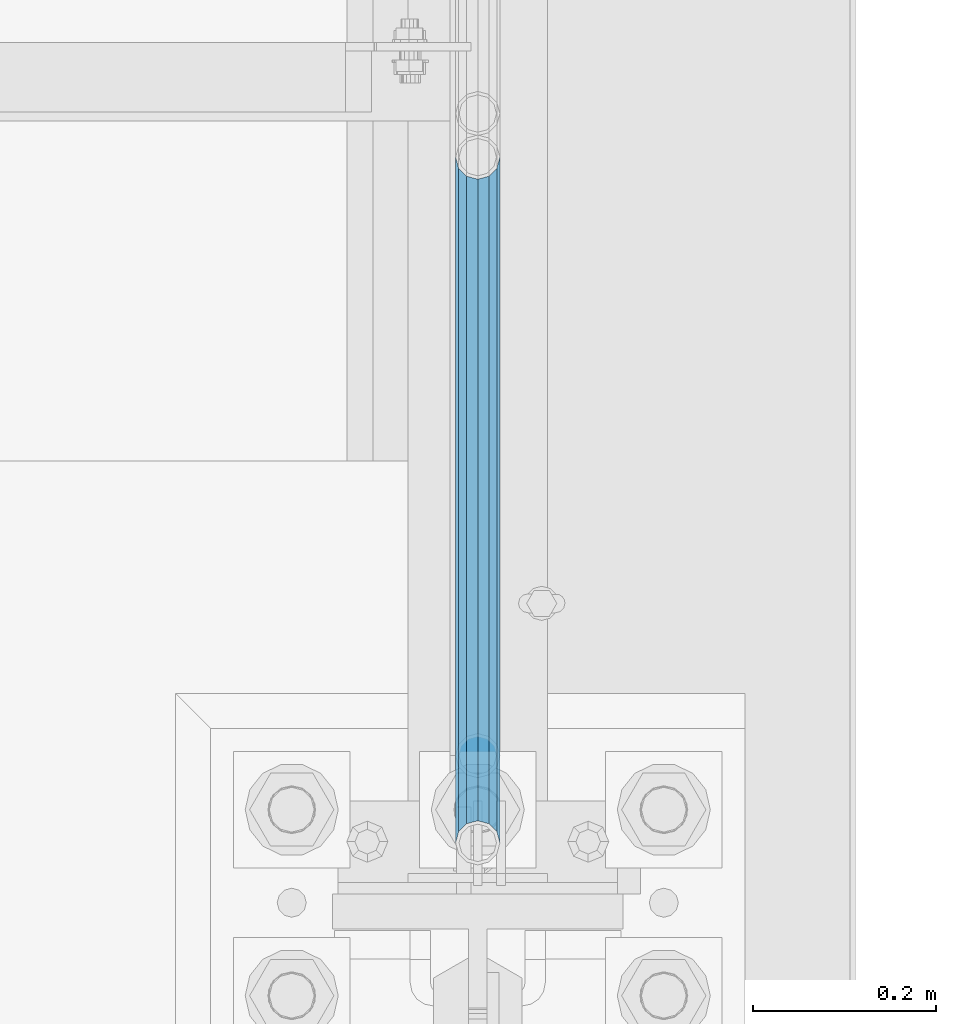
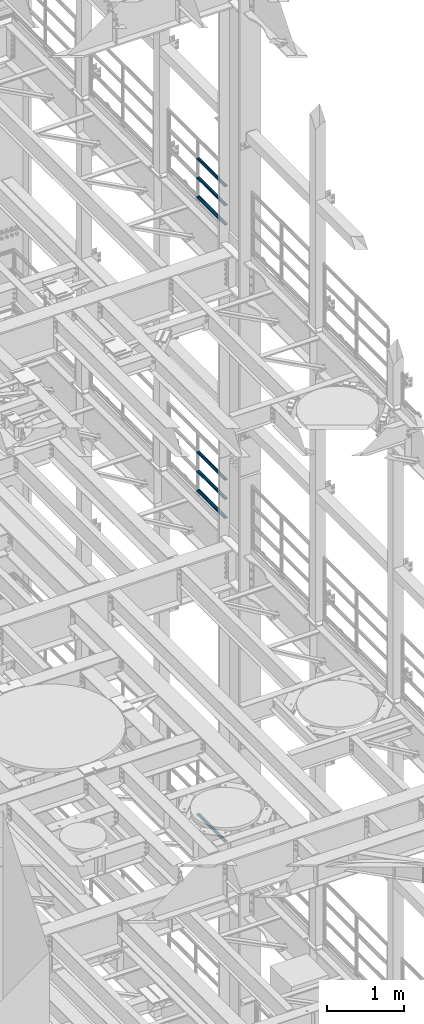
# One storey, part 1341 of 1876: 7 beams, 3 elements without a shape of their own.
"""IFC2X3 building model written with IfcOpenShell, lengths in millimetres."""

from ifc_helpers import new_model, si_unit, frame, origin_with_axes, place, context, subcontext, project, spatial, faceted_brep, material, type_object, element, aggregate, save


model = new_model("IFC2X3")

# Units and contexts
model_context = context("Model", 3, precision=1e-05, world=origin_with_axes())
body_context = subcontext(model_context, "Body", "Model", "MODEL_VIEW")
ifc_project = project(units=[si_unit("LENGTHUNIT", "METRE", prefix="MILLI"), si_unit("AREAUNIT", "SQUARE_METRE"), si_unit("VOLUMEUNIT", "CUBIC_METRE"), si_unit("MASSUNIT", "GRAM", prefix="KILO"), si_unit("TIMEUNIT", "SECOND"), si_unit("PLANEANGLEUNIT", "RADIAN"), si_unit("SOLIDANGLEUNIT", "STERADIAN"), si_unit("THERMODYNAMICTEMPERATUREUNIT", "DEGREE_CELSIUS"), si_unit("LUMINOUSINTENSITYUNIT", "LUMEN")], contexts=[model_context])

# Site, building, storey
site_placement = place(None, origin_with_axes())
site = spatial("IfcSite", under=ifc_project, at=site_placement, CompositionType="ELEMENT")
building_placement = place(site_placement, origin_with_axes())
building = spatial("IfcBuilding", under=site, at=building_placement, Name="Undefined", CompositionType="ELEMENT")
storey_placement = place(building_placement, origin_with_axes())
storey = spatial("IfcBuildingStorey", under=building, at=storey_placement, Name="Undefined", CompositionType="ELEMENT", Elevation=0.0)

# Assembly, beams
assembly_1_placement = place(storey_placement, origin_with_axes())
assembly_1 = element("IfcElementAssembly", 1, at=assembly_1_placement, inside=storey, Name="RAIL", AssemblyPlace="NOTDEFINED", PredefinedType="RIGID_FRAME")
ifc_material = material()
beam_type = type_object("IfcBeamType", Name="PIPE1-1/2SCH40", PredefinedType="NOTDEFINED")
beam_1_placement = place(assembly_1_placement, frame((7620.0, 8713.7875, 18145.125), z_axis=(0.0, 0.0, 1.0), x_axis=(0.0, -1.0, 0.0)))
beam_1 = element("IfcBeam", 2, at=beam_1_placement, type_object=beam_type, material=ifc_material, Name="RAIL", ObjectType="PIPE1-1/2SCH40", context=body_context, shape_type="Brep", body=[
    faceted_brep([(728.085307006683, -12.0649999999996, 20.8971929933177), (728.085307006683, -12.0649999999996, 15.8661214311796), (727.591878568821, -10.2235000000001, 17.7076214311819), (724.852500000002, 0.0, 20.4470000000001), (724.852500000002, 0.0, 24.130000000001), (727.591878568821, 10.2235000000001, 17.7076214311819), (728.085307006683, 12.0649999999996, 15.8661214311796), (728.085307006683, 12.0649999999996, 20.8971929933177), (748.982500000002, 24.1300000000001, 0.0), (736.917500000002, 20.8971929933186, 12.0649999999987), (736.917500000002, 20.8971929933186, -12.0649999999987), (733.727928437864, 17.7076214311801, 10.2235000000001), (736.467307006683, 20.4470000000001, 0.0), (733.727928437864, 17.7076214311801, -10.2235000000001), (728.085307006683, 12.0649999999996, -15.8661214311796), (728.085307006683, 12.0649999999996, -20.8971929933177), (727.591878568821, 10.2235000000001, -17.7076214311819), (724.852500000002, 0.0, -20.4470000000001), (724.852500000002, 0.0, -24.130000000001), (728.085307006683, -12.0649999999996, -15.8661214311796), (728.085307006683, -12.0649999999996, -20.8971929933177), (727.591878568821, -10.2235000000001, -17.7076214311819), (748.982500000002, -24.1300000000001, 0.0), (736.917500000002, -20.8971929933186, -12.0649999999987), (736.917500000002, -20.8971929933186, 12.0649999999987), (733.727928437864, -17.7076214311801, -10.2235000000001), (736.467307006683, -20.4470000000001, 0.0), (733.727928437864, -17.7076214311801, 10.2235000000001), (12.0650000000064, -20.8971929933177, -12.0649999999987), (20.8971929933249, -12.0650000000005, -20.8971929933177), (0.0, 24.1299999999992, 0.0), (12.0650000000064, 20.8971929933177, -12.0649999999987), (12.0650000000064, 20.8971929933177, 12.0649999999987), (20.8971929933249, 12.0650000000005, 20.8971929933177), (24.1300000000064, 0.0, 24.130000000001), (20.8971929933249, 12.0650000000005, -20.8971929933177), (24.1300000000063, 0.0, -24.130000000001), (24.1300000000063, 0.0, -20.4470000000001), (20.8971929933249, -12.0650000000005, -15.8661214311796), (21.3906214311868, -10.2235000000001, -17.7076214311819), (21.3906214311868, 10.2235000000001, -17.7076214311819), (20.8971929933249, 12.0650000000005, -15.8661214311796), (15.2545715621445, 17.7076214311801, -10.2235000000001), (12.5151929933249, 20.4470000000001, 0.0), (15.2545715621445, 17.7076214311801, 10.2235000000001), (20.8971929933249, 12.0650000000005, 15.8661214311796), (21.3906214311868, 10.2235000000001, 17.7076214311819), (24.1300000000064, 0.0, 20.4470000000001), (21.3906214311868, -10.2235000000001, 17.7076214311819), (20.8971929933249, -12.0650000000005, 15.8661214311796), (20.8971929933249, -12.0650000000005, 20.8971929933177), (12.0650000000064, -20.8971929933177, 12.0649999999987), (0.0, -24.1299999999992, 0.0), (15.2545715621445, -17.7076214311801, 10.2235000000001), (12.5151929933249, -20.4470000000001, 0.0), (15.2545715621445, -17.7076214311801, -10.2235000000001)], [[[0, 1, 2, 3, 4]], [[4, 3, 5, 6, 7]], [[8, 9, 10]], [[7, 6, 11, 12, 13, 14, 15, 10, 9]], [[16, 17, 18, 15, 14]], [[19, 20, 18, 17, 21]], [[22, 23, 24]], [[24, 23, 20, 19, 25, 26, 27, 1, 0]], [[28, 29, 20, 23]], [[30, 31, 32]], [[33, 34, 4, 7]], [[32, 33, 7, 9]], [[30, 32, 9, 8]], [[31, 30, 8, 10]], [[35, 31, 10, 15]], [[36, 35, 15, 18]], [[29, 36, 18, 20]], [[37, 36, 29, 38, 39]], [[40, 41, 35, 36, 37]], [[32, 31, 35, 41, 42, 43, 44, 45, 33]], [[33, 45, 46, 47, 34]], [[34, 47, 48, 49, 50]], [[34, 50, 0, 4]], [[50, 51, 24, 0]], [[51, 52, 22, 24]], [[52, 28, 23, 22]], [[51, 28, 52]], [[50, 49, 53, 54, 55, 38, 29, 28, 51]], [[55, 54, 26, 25]], [[21, 39, 38, 55, 25, 19]], [[37, 39, 21, 17]], [[40, 37, 17, 16]], [[42, 41, 40, 16, 14, 13]], [[43, 42, 13, 12]], [[44, 43, 12, 11]], [[5, 46, 45, 44, 11, 6]], [[47, 46, 5, 3]], [[48, 47, 3, 2]], [[53, 49, 48, 2, 1, 27]], [[54, 53, 27, 26]]]),
])
beam_2_placement = place(assembly_1_placement, frame((7620.0, 7964.805, 18449.925), z_axis=(0.0, 0.0, -1.0), x_axis=(0.0, 1.0, 0.0)))
beam_2 = element("IfcBeam", 3, at=beam_2_placement, type_object=beam_type, material=ifc_material, Name="RAIL", ObjectType="PIPE1-1/2SCH40", context=body_context, shape_type="Brep", body=[
    faceted_brep([(0.0, 24.1299999999992, 0.0), (12.0650000000064, 20.8971929933177, -12.0649999999987), (12.0650000000064, 20.8971929933177, 12.0649999999987), (12.0650000000064, -20.8971929933177, 12.0649999999987), (12.0650000000064, -20.8971929933177, -12.0649999999987), (0.0, -24.1299999999992, 0.0), (20.8971929933249, -12.0650000000005, 20.8971929933177), (20.8971929933249, -12.0650000000005, 15.8661214311796), (15.2545715621445, -17.7076214311801, 10.2235000000001), (12.5151929933249, -20.4470000000001, 0.0), (15.2545715621445, -17.7076214311801, -10.2235000000001), (20.8971929933249, -12.0650000000005, -15.8661214311796), (20.8971929933249, -12.0650000000005, -20.8971929933177), (24.1300000000063, 0.0, -20.4470000000001), (24.1300000000063, 0.0, -24.130000000001), (21.3906214311868, -10.2235000000001, -17.7076214311819), (21.3906214311868, 10.2235000000001, -17.7076214311819), (20.8971929933249, 12.0650000000005, -15.8661214311796), (20.8971929933249, 12.0650000000005, -20.8971929933177), (15.2545715621445, 17.7076214311801, -10.2235000000001), (12.5151929933249, 20.4470000000001, 0.0), (15.2545715621445, 17.7076214311801, 10.2235000000001), (20.8971929933249, 12.0650000000005, 15.8661214311796), (20.8971929933249, 12.0650000000005, 20.8971929933177), (21.3906214311868, 10.2235000000001, 17.7076214311819), (24.1300000000064, 0.0, 20.4470000000001), (24.1300000000064, 0.0, 24.130000000001), (21.3906214311868, -10.2235000000001, 17.7076214311819), (748.982500000002, 24.1300000000001, 0.0), (736.917500000002, 20.8971929933186, -12.0649999999987), (728.085307006683, 12.0649999999996, -20.8971929933177), (748.982500000002, -24.1300000000001, 0.0), (736.917500000002, -20.8971929933186, -12.0649999999987), (736.917500000002, -20.8971929933186, 12.0649999999987), (728.085307006683, -12.0649999999996, 20.8971929933177), (728.085307006683, -12.0649999999996, -20.8971929933177), (724.852500000002, 0.0, -24.130000000001), (727.591878568821, 10.2235000000001, -17.7076214311819), (724.852500000002, 0.0, -20.4470000000001), (728.085307006683, 12.0649999999996, -15.8661214311796), (728.085307006683, -12.0649999999996, -15.8661214311796), (727.591878568821, -10.2235000000001, -17.7076214311819), (733.727928437864, -17.7076214311801, -10.2235000000001), (736.467307006683, -20.4470000000001, 0.0), (733.727928437864, -17.7076214311801, 10.2235000000001), (728.085307006683, -12.0649999999996, 15.8661214311796), (727.591878568821, -10.2235000000001, 17.7076214311819), (724.852500000002, 0.0, 20.4470000000001), (724.852500000002, 0.0, 24.130000000001), (728.085307006683, 12.0649999999996, 20.8971929933177), (736.917500000002, 20.8971929933186, 12.0649999999987), (728.085307006683, 12.0649999999996, 15.8661214311796), (733.727928437864, 17.7076214311801, 10.2235000000001), (736.467307006683, 20.4470000000001, 0.0), (733.727928437864, 17.7076214311801, -10.2235000000001), (727.591878568821, 10.2235000000001, 17.7076214311819)], [[[0, 1, 2]], [[3, 4, 5]], [[6, 7, 8, 9, 10, 11, 12, 4, 3]], [[13, 14, 12, 11, 15]], [[16, 17, 18, 14, 13]], [[2, 1, 18, 17, 19, 20, 21, 22, 23]], [[23, 22, 24, 25, 26]], [[26, 25, 27, 7, 6]], [[1, 0, 28, 29]], [[18, 1, 29, 30]], [[31, 32, 33]], [[6, 3, 33, 34]], [[3, 5, 31, 33]], [[5, 4, 32, 31]], [[4, 12, 35, 32]], [[12, 14, 36, 35]], [[14, 18, 30, 36]], [[37, 38, 36, 30, 39]], [[40, 35, 36, 38, 41]], [[33, 32, 35, 40, 42, 43, 44, 45, 34]], [[34, 45, 46, 47, 48]], [[26, 6, 34, 48]], [[2, 23, 49, 50]], [[23, 26, 48, 49]], [[0, 2, 50, 28]], [[28, 50, 29]], [[49, 51, 52, 53, 54, 39, 30, 29, 50]], [[48, 47, 55, 51, 49]], [[25, 24, 55, 47]], [[55, 24, 22, 21, 52, 51]], [[21, 20, 53, 52]], [[20, 19, 54, 53]], [[19, 17, 16, 37, 39, 54]], [[16, 13, 38, 37]], [[13, 15, 41, 38]], [[41, 15, 11, 10, 42, 40]], [[10, 9, 43, 42]], [[9, 8, 44, 43]], [[8, 7, 27, 46, 45, 44]], [[27, 25, 47, 46]]]),
])
beam_3_placement = place(assembly_1_placement, frame((7620.0, 7964.805, 18754.725), z_axis=(0.0, 0.0, -1.0), x_axis=(0.0, 1.0, 0.0)))
beam_3 = element("IfcBeam", 4, at=beam_3_placement, type_object=beam_type, material=ifc_material, Name="RAIL", ObjectType="PIPE1-1/2SCH40", context=body_context, shape_type="Brep", body=[
    faceted_brep([(0.0, 24.1299999999992, 0.0), (12.0650000000064, 20.8971929933177, -12.0649999999987), (12.0650000000064, 20.8971929933177, 12.0649999999987), (12.0650000000064, -20.8971929933177, 12.0649999999987), (12.0650000000064, -20.8971929933177, -12.0649999999987), (0.0, -24.1299999999992, 0.0), (20.8971929933249, -12.0650000000005, 20.8971929933177), (20.8971929933249, -12.0650000000005, 15.8661214311796), (15.2545715621445, -17.7076214311801, 10.2235000000001), (12.5151929933249, -20.4470000000001, 0.0), (15.2545715621445, -17.7076214311801, -10.2235000000001), (20.8971929933249, -12.0650000000005, -15.8661214311796), (20.8971929933249, -12.0650000000005, -20.8971929933177), (24.1300000000063, 0.0, -20.4470000000001), (24.1300000000063, 0.0, -24.130000000001), (21.3906214311868, -10.2235000000001, -17.7076214311819), (21.3906214311868, 10.2235000000001, -17.7076214311819), (20.8971929933249, 12.0650000000005, -15.8661214311796), (20.8971929933249, 12.0650000000005, -20.8971929933177), (15.2545715621445, 17.7076214311801, -10.2235000000001), (12.5151929933249, 20.4470000000001, 0.0), (15.2545715621445, 17.7076214311801, 10.2235000000001), (20.8971929933249, 12.0650000000005, 15.8661214311796), (20.8971929933249, 12.0650000000005, 20.8971929933177), (21.3906214311868, 10.2235000000001, 17.7076214311819), (24.1300000000064, 0.0, 20.4470000000001), (24.1300000000064, 0.0, 24.130000000001), (21.3906214311868, -10.2235000000001, 17.7076214311819), (748.982500000002, 24.1300000000001, 0.0), (736.917500000002, 20.8971929933186, -12.0649999999987), (728.085307006683, 12.0649999999996, -20.8971929933177), (748.982500000002, -24.1300000000001, 0.0), (736.917500000002, -20.8971929933186, -12.0649999999987), (736.917500000002, -20.8971929933186, 12.0649999999987), (728.085307006683, -12.0649999999996, 20.8971929933177), (728.085307006683, -12.0649999999996, -20.8971929933177), (724.852500000002, 0.0, -24.130000000001), (727.591878568821, 10.2235000000001, -17.7076214311819), (724.852500000002, 0.0, -20.4470000000001), (728.085307006683, 12.0649999999996, -15.8661214311796), (728.085307006683, -12.0649999999996, -15.8661214311796), (727.591878568821, -10.2235000000001, -17.7076214311819), (733.727928437864, -17.7076214311801, -10.2235000000001), (736.467307006683, -20.4470000000001, 0.0), (733.727928437864, -17.7076214311801, 10.2235000000001), (728.085307006683, -12.0649999999996, 15.8661214311796), (727.591878568821, -10.2235000000001, 17.7076214311819), (724.852500000002, 0.0, 20.4470000000001), (724.852500000002, 0.0, 24.130000000001), (728.085307006683, 12.0649999999996, 20.8971929933177), (736.917500000002, 20.8971929933186, 12.0649999999987), (728.085307006683, 12.0649999999996, 15.8661214311796), (733.727928437864, 17.7076214311801, 10.2235000000001), (736.467307006683, 20.4470000000001, 0.0), (733.727928437864, 17.7076214311801, -10.2235000000001), (727.591878568821, 10.2235000000001, 17.7076214311819)], [[[0, 1, 2]], [[3, 4, 5]], [[6, 7, 8, 9, 10, 11, 12, 4, 3]], [[13, 14, 12, 11, 15]], [[16, 17, 18, 14, 13]], [[2, 1, 18, 17, 19, 20, 21, 22, 23]], [[23, 22, 24, 25, 26]], [[26, 25, 27, 7, 6]], [[1, 0, 28, 29]], [[18, 1, 29, 30]], [[31, 32, 33]], [[6, 3, 33, 34]], [[3, 5, 31, 33]], [[5, 4, 32, 31]], [[4, 12, 35, 32]], [[12, 14, 36, 35]], [[14, 18, 30, 36]], [[37, 38, 36, 30, 39]], [[40, 35, 36, 38, 41]], [[33, 32, 35, 40, 42, 43, 44, 45, 34]], [[34, 45, 46, 47, 48]], [[26, 6, 34, 48]], [[2, 23, 49, 50]], [[23, 26, 48, 49]], [[0, 2, 50, 28]], [[28, 50, 29]], [[49, 51, 52, 53, 54, 39, 30, 29, 50]], [[48, 47, 55, 51, 49]], [[25, 24, 55, 47]], [[55, 24, 22, 21, 52, 51]], [[21, 20, 53, 52]], [[20, 19, 54, 53]], [[19, 17, 16, 37, 39, 54]], [[16, 13, 38, 37]], [[13, 15, 41, 38]], [[41, 15, 11, 10, 42, 40]], [[10, 9, 43, 42]], [[9, 8, 44, 43]], [[8, 7, 27, 46, 45, 44]], [[27, 25, 47, 46]]]),
])
aggregate(assembly_1, [beam_1, beam_2, beam_3])

assembly_2_placement = place(storey_placement, origin_with_axes())
assembly_2 = element("IfcElementAssembly", 5, at=assembly_2_placement, inside=storey, Name="RAIL", AssemblyPlace="NOTDEFINED", PredefinedType="RIGID_FRAME")
beam_4_placement = place(assembly_2_placement, frame((7620.0, 8713.7875, 13471.525), z_axis=(0.0, 0.0, 1.0), x_axis=(0.0, -1.0, 0.0)))
beam_4 = element("IfcBeam", 6, at=beam_4_placement, type_object=beam_type, material=ifc_material, Name="RAIL", ObjectType="PIPE1-1/2SCH40", context=body_context, shape_type="Brep", body=[
    faceted_brep([(728.085307006683, -12.0649999999996, 20.8971929933177), (728.085307006683, -12.0649999999996, 15.8661214311796), (727.591878568821, -10.2235000000001, 17.7076214311819), (724.852500000002, 0.0, 20.4470000000001), (724.852500000002, 0.0, 24.130000000001), (727.591878568821, 10.2235000000001, 17.7076214311819), (728.085307006683, 12.0649999999996, 15.8661214311796), (728.085307006683, 12.0649999999996, 20.8971929933177), (748.982500000002, 24.1300000000001, 0.0), (736.917500000002, 20.8971929933186, 12.0649999999987), (736.917500000002, 20.8971929933186, -12.0649999999987), (733.727928437864, 17.7076214311801, 10.2235000000001), (736.467307006683, 20.4470000000001, 0.0), (733.727928437864, 17.7076214311801, -10.2235000000001), (728.085307006683, 12.0649999999996, -15.8661214311796), (728.085307006683, 12.0649999999996, -20.8971929933177), (727.591878568821, 10.2235000000001, -17.7076214311819), (724.852500000002, 0.0, -20.4470000000001), (724.852500000002, 0.0, -24.130000000001), (728.085307006683, -12.0649999999996, -15.8661214311796), (728.085307006683, -12.0649999999996, -20.8971929933177), (727.591878568821, -10.2235000000001, -17.7076214311819), (748.982500000002, -24.1300000000001, 0.0), (736.917500000002, -20.8971929933186, -12.0649999999987), (736.917500000002, -20.8971929933186, 12.0649999999987), (733.727928437864, -17.7076214311801, -10.2235000000001), (736.467307006683, -20.4470000000001, 0.0), (733.727928437864, -17.7076214311801, 10.2235000000001), (12.0650000000064, -20.8971929933177, -12.0649999999987), (20.8971929933249, -12.0650000000005, -20.8971929933177), (0.0, 24.1299999999992, 0.0), (12.0650000000064, 20.8971929933177, -12.0649999999987), (12.0650000000064, 20.8971929933177, 12.0649999999987), (20.8971929933249, 12.0650000000005, 20.8971929933177), (24.1300000000064, 0.0, 24.130000000001), (20.8971929933249, 12.0650000000005, -20.8971929933177), (24.1300000000063, 0.0, -24.130000000001), (24.1300000000063, 0.0, -20.4470000000001), (20.8971929933249, -12.0650000000005, -15.8661214311796), (21.3906214311868, -10.2235000000001, -17.7076214311819), (21.3906214311868, 10.2235000000001, -17.7076214311819), (20.8971929933249, 12.0650000000005, -15.8661214311796), (15.2545715621445, 17.7076214311801, -10.2235000000001), (12.5151929933249, 20.4470000000001, 0.0), (15.2545715621445, 17.7076214311801, 10.2235000000001), (20.8971929933249, 12.0650000000005, 15.8661214311796), (21.3906214311868, 10.2235000000001, 17.7076214311819), (24.1300000000064, 0.0, 20.4470000000001), (21.3906214311868, -10.2235000000001, 17.7076214311819), (20.8971929933249, -12.0650000000005, 15.8661214311796), (20.8971929933249, -12.0650000000005, 20.8971929933177), (12.0650000000064, -20.8971929933177, 12.0649999999987), (0.0, -24.1299999999992, 0.0), (15.2545715621445, -17.7076214311801, 10.2235000000001), (12.5151929933249, -20.4470000000001, 0.0), (15.2545715621445, -17.7076214311801, -10.2235000000001)], [[[0, 1, 2, 3, 4]], [[4, 3, 5, 6, 7]], [[8, 9, 10]], [[7, 6, 11, 12, 13, 14, 15, 10, 9]], [[16, 17, 18, 15, 14]], [[19, 20, 18, 17, 21]], [[22, 23, 24]], [[24, 23, 20, 19, 25, 26, 27, 1, 0]], [[28, 29, 20, 23]], [[30, 31, 32]], [[33, 34, 4, 7]], [[32, 33, 7, 9]], [[30, 32, 9, 8]], [[31, 30, 8, 10]], [[35, 31, 10, 15]], [[36, 35, 15, 18]], [[29, 36, 18, 20]], [[37, 36, 29, 38, 39]], [[40, 41, 35, 36, 37]], [[32, 31, 35, 41, 42, 43, 44, 45, 33]], [[33, 45, 46, 47, 34]], [[34, 47, 48, 49, 50]], [[34, 50, 0, 4]], [[50, 51, 24, 0]], [[51, 52, 22, 24]], [[52, 28, 23, 22]], [[51, 28, 52]], [[50, 49, 53, 54, 55, 38, 29, 28, 51]], [[55, 54, 26, 25]], [[21, 39, 38, 55, 25, 19]], [[37, 39, 21, 17]], [[40, 37, 17, 16]], [[42, 41, 40, 16, 14, 13]], [[43, 42, 13, 12]], [[44, 43, 12, 11]], [[5, 46, 45, 44, 11, 6]], [[47, 46, 5, 3]], [[48, 47, 3, 2]], [[53, 49, 48, 2, 1, 27]], [[54, 53, 27, 26]]]),
])
beam_5_placement = place(assembly_2_placement, frame((7620.0, 7964.805, 13776.325), z_axis=(0.0, 0.0, -1.0), x_axis=(0.0, 1.0, 0.0)))
beam_5 = element("IfcBeam", 7, at=beam_5_placement, type_object=beam_type, material=ifc_material, Name="RAIL", ObjectType="PIPE1-1/2SCH40", context=body_context, shape_type="Brep", body=[
    faceted_brep([(0.0, 24.1299999999992, 0.0), (12.0650000000064, 20.8971929933177, -12.0649999999987), (12.0650000000064, 20.8971929933177, 12.0649999999987), (12.0650000000064, -20.8971929933177, 12.0649999999987), (12.0650000000064, -20.8971929933177, -12.0649999999987), (0.0, -24.1299999999992, 0.0), (20.8971929933249, -12.0650000000005, 20.8971929933177), (20.8971929933249, -12.0650000000005, 15.8661214311796), (15.2545715621445, -17.7076214311801, 10.2235000000001), (12.5151929933249, -20.4470000000001, 0.0), (15.2545715621445, -17.7076214311801, -10.2235000000001), (20.8971929933249, -12.0650000000005, -15.8661214311796), (20.8971929933249, -12.0650000000005, -20.8971929933177), (24.1300000000063, 0.0, -20.4470000000001), (24.1300000000063, 0.0, -24.130000000001), (21.3906214311868, -10.2235000000001, -17.7076214311819), (21.3906214311868, 10.2235000000001, -17.7076214311819), (20.8971929933249, 12.0650000000005, -15.8661214311796), (20.8971929933249, 12.0650000000005, -20.8971929933177), (15.2545715621445, 17.7076214311801, -10.2235000000001), (12.5151929933249, 20.4470000000001, 0.0), (15.2545715621445, 17.7076214311801, 10.2235000000001), (20.8971929933249, 12.0650000000005, 15.8661214311796), (20.8971929933249, 12.0650000000005, 20.8971929933177), (21.3906214311868, 10.2235000000001, 17.7076214311819), (24.1300000000064, 0.0, 20.4470000000001), (24.1300000000064, 0.0, 24.130000000001), (21.3906214311868, -10.2235000000001, 17.7076214311819), (748.982500000002, 24.1300000000001, 0.0), (736.917500000002, 20.8971929933186, -12.0649999999987), (728.085307006683, 12.0649999999996, -20.8971929933177), (748.982500000002, -24.1300000000001, 0.0), (736.917500000002, -20.8971929933186, -12.0649999999987), (736.917500000002, -20.8971929933186, 12.0649999999987), (728.085307006683, -12.0649999999996, 20.8971929933177), (728.085307006683, -12.0649999999996, -20.8971929933177), (724.852500000002, 0.0, -24.130000000001), (727.591878568821, 10.2235000000001, -17.7076214311819), (724.852500000002, 0.0, -20.4470000000001), (728.085307006683, 12.0649999999996, -15.8661214311796), (728.085307006683, -12.0649999999996, -15.8661214311796), (727.591878568821, -10.2235000000001, -17.7076214311819), (733.727928437864, -17.7076214311801, -10.2235000000001), (736.467307006683, -20.4470000000001, 0.0), (733.727928437864, -17.7076214311801, 10.2235000000001), (728.085307006683, -12.0649999999996, 15.8661214311796), (727.591878568821, -10.2235000000001, 17.7076214311819), (724.852500000002, 0.0, 20.4470000000001), (724.852500000002, 0.0, 24.130000000001), (728.085307006683, 12.0649999999996, 20.8971929933177), (736.917500000002, 20.8971929933186, 12.0649999999987), (728.085307006683, 12.0649999999996, 15.8661214311796), (733.727928437864, 17.7076214311801, 10.2235000000001), (736.467307006683, 20.4470000000001, 0.0), (733.727928437864, 17.7076214311801, -10.2235000000001), (727.591878568821, 10.2235000000001, 17.7076214311819)], [[[0, 1, 2]], [[3, 4, 5]], [[6, 7, 8, 9, 10, 11, 12, 4, 3]], [[13, 14, 12, 11, 15]], [[16, 17, 18, 14, 13]], [[2, 1, 18, 17, 19, 20, 21, 22, 23]], [[23, 22, 24, 25, 26]], [[26, 25, 27, 7, 6]], [[1, 0, 28, 29]], [[18, 1, 29, 30]], [[31, 32, 33]], [[6, 3, 33, 34]], [[3, 5, 31, 33]], [[5, 4, 32, 31]], [[4, 12, 35, 32]], [[12, 14, 36, 35]], [[14, 18, 30, 36]], [[37, 38, 36, 30, 39]], [[40, 35, 36, 38, 41]], [[33, 32, 35, 40, 42, 43, 44, 45, 34]], [[34, 45, 46, 47, 48]], [[26, 6, 34, 48]], [[2, 23, 49, 50]], [[23, 26, 48, 49]], [[0, 2, 50, 28]], [[28, 50, 29]], [[49, 51, 52, 53, 54, 39, 30, 29, 50]], [[48, 47, 55, 51, 49]], [[25, 24, 55, 47]], [[55, 24, 22, 21, 52, 51]], [[21, 20, 53, 52]], [[20, 19, 54, 53]], [[19, 17, 16, 37, 39, 54]], [[16, 13, 38, 37]], [[13, 15, 41, 38]], [[41, 15, 11, 10, 42, 40]], [[10, 9, 43, 42]], [[9, 8, 44, 43]], [[8, 7, 27, 46, 45, 44]], [[27, 25, 47, 46]]]),
])
beam_6_placement = place(assembly_2_placement, frame((7620.0, 7964.805, 14081.125), z_axis=(0.0, 0.0, -1.0), x_axis=(0.0, 1.0, 0.0)))
beam_6 = element("IfcBeam", 8, at=beam_6_placement, type_object=beam_type, material=ifc_material, Name="RAIL", ObjectType="PIPE1-1/2SCH40", context=body_context, shape_type="Brep", body=[
    faceted_brep([(0.0, 24.1299999999992, 0.0), (12.0650000000064, 20.8971929933177, -12.0649999999987), (12.0650000000064, 20.8971929933177, 12.0649999999987), (12.0650000000064, -20.8971929933177, 12.0649999999987), (12.0650000000064, -20.8971929933177, -12.0649999999987), (0.0, -24.1299999999992, 0.0), (20.8971929933249, -12.0650000000005, 20.8971929933177), (20.8971929933249, -12.0650000000005, 15.8661214311796), (15.2545715621445, -17.7076214311801, 10.2235000000001), (12.5151929933249, -20.4470000000001, 0.0), (15.2545715621445, -17.7076214311801, -10.2235000000001), (20.8971929933249, -12.0650000000005, -15.8661214311796), (20.8971929933249, -12.0650000000005, -20.8971929933177), (24.1300000000063, 0.0, -20.4470000000001), (24.1300000000063, 0.0, -24.130000000001), (21.3906214311868, -10.2235000000001, -17.7076214311819), (21.3906214311868, 10.2235000000001, -17.7076214311819), (20.8971929933249, 12.0650000000005, -15.8661214311796), (20.8971929933249, 12.0650000000005, -20.8971929933177), (15.2545715621445, 17.7076214311801, -10.2235000000001), (12.5151929933249, 20.4470000000001, 0.0), (15.2545715621445, 17.7076214311801, 10.2235000000001), (20.8971929933249, 12.0650000000005, 15.8661214311796), (20.8971929933249, 12.0650000000005, 20.8971929933177), (21.3906214311868, 10.2235000000001, 17.7076214311819), (24.1300000000064, 0.0, 20.4470000000001), (24.1300000000064, 0.0, 24.130000000001), (21.3906214311868, -10.2235000000001, 17.7076214311819), (748.982500000002, 24.1300000000001, 0.0), (736.917500000002, 20.8971929933186, -12.0649999999987), (728.085307006683, 12.0649999999996, -20.8971929933177), (748.982500000002, -24.1300000000001, 0.0), (736.917500000002, -20.8971929933186, -12.0649999999987), (736.917500000002, -20.8971929933186, 12.0649999999987), (728.085307006683, -12.0649999999996, 20.8971929933177), (728.085307006683, -12.0649999999996, -20.8971929933177), (724.852500000002, 0.0, -24.130000000001), (727.591878568821, 10.2235000000001, -17.7076214311819), (724.852500000002, 0.0, -20.4470000000001), (728.085307006683, 12.0649999999996, -15.8661214311796), (728.085307006683, -12.0649999999996, -15.8661214311796), (727.591878568821, -10.2235000000001, -17.7076214311819), (733.727928437864, -17.7076214311801, -10.2235000000001), (736.467307006683, -20.4470000000001, 0.0), (733.727928437864, -17.7076214311801, 10.2235000000001), (728.085307006683, -12.0649999999996, 15.8661214311796), (727.591878568821, -10.2235000000001, 17.7076214311819), (724.852500000002, 0.0, 20.4470000000001), (724.852500000002, 0.0, 24.130000000001), (728.085307006683, 12.0649999999996, 20.8971929933177), (736.917500000002, 20.8971929933186, 12.0649999999987), (728.085307006683, 12.0649999999996, 15.8661214311796), (733.727928437864, 17.7076214311801, 10.2235000000001), (736.467307006683, 20.4470000000001, 0.0), (733.727928437864, 17.7076214311801, -10.2235000000001), (727.591878568821, 10.2235000000001, 17.7076214311819)], [[[0, 1, 2]], [[3, 4, 5]], [[6, 7, 8, 9, 10, 11, 12, 4, 3]], [[13, 14, 12, 11, 15]], [[16, 17, 18, 14, 13]], [[2, 1, 18, 17, 19, 20, 21, 22, 23]], [[23, 22, 24, 25, 26]], [[26, 25, 27, 7, 6]], [[1, 0, 28, 29]], [[18, 1, 29, 30]], [[31, 32, 33]], [[6, 3, 33, 34]], [[3, 5, 31, 33]], [[5, 4, 32, 31]], [[4, 12, 35, 32]], [[12, 14, 36, 35]], [[14, 18, 30, 36]], [[37, 38, 36, 30, 39]], [[40, 35, 36, 38, 41]], [[33, 32, 35, 40, 42, 43, 44, 45, 34]], [[34, 45, 46, 47, 48]], [[26, 6, 34, 48]], [[2, 23, 49, 50]], [[23, 26, 48, 49]], [[0, 2, 50, 28]], [[28, 50, 29]], [[49, 51, 52, 53, 54, 39, 30, 29, 50]], [[48, 47, 55, 51, 49]], [[25, 24, 55, 47]], [[55, 24, 22, 21, 52, 51]], [[21, 20, 53, 52]], [[20, 19, 54, 53]], [[19, 17, 16, 37, 39, 54]], [[16, 13, 38, 37]], [[13, 15, 41, 38]], [[41, 15, 11, 10, 42, 40]], [[10, 9, 43, 42]], [[9, 8, 44, 43]], [[8, 7, 27, 46, 45, 44]], [[27, 25, 47, 46]]]),
])
aggregate(assembly_2, [beam_4, beam_5, beam_6])

# Assembly, beam
assembly_3_placement = place(storey_placement, origin_with_axes())
assembly_3 = element("IfcElementAssembly", 9, at=assembly_3_placement, inside=storey, Name="RAIL", AssemblyPlace="NOTDEFINED", PredefinedType="RIGID_FRAME")
beam_7_placement = place(assembly_3_placement, frame((7620.0, 8713.7875, 8315.325), z_axis=(0.0, 0.0, 1.0), x_axis=(0.0, -1.0, 0.0)))
beam_7 = element("IfcBeam", 10, at=beam_7_placement, type_object=beam_type, material=ifc_material, Name="RAIL", ObjectType="PIPE1-1/2SCH40", context=body_context, shape_type="Brep", body=[
    faceted_brep([(728.085307006683, -12.0649999999996, 20.8971929933177), (728.085307006683, -12.0649999999996, 15.8661214311796), (727.591878568821, -10.2235000000001, 17.7076214311819), (724.852500000002, 0.0, 20.4470000000001), (724.852500000002, 0.0, 24.130000000001), (727.591878568821, 10.2235000000001, 17.7076214311819), (728.085307006683, 12.0649999999996, 15.8661214311796), (728.085307006683, 12.0649999999996, 20.8971929933177), (748.982500000002, 24.1300000000001, 0.0), (736.917500000002, 20.8971929933186, 12.0649999999987), (736.917500000002, 20.8971929933186, -12.0649999999987), (733.727928437864, 17.7076214311801, 10.2235000000001), (736.467307006683, 20.4470000000001, 0.0), (733.727928437864, 17.7076214311801, -10.2235000000001), (728.085307006683, 12.0649999999996, -15.8661214311796), (728.085307006683, 12.0649999999996, -20.8971929933177), (727.591878568821, 10.2235000000001, -17.7076214311819), (724.852500000002, 0.0, -20.4470000000001), (724.852500000002, 0.0, -24.130000000001), (728.085307006683, -12.0649999999996, -15.8661214311796), (728.085307006683, -12.0649999999996, -20.8971929933177), (727.591878568821, -10.2235000000001, -17.7076214311819), (748.982500000002, -24.1300000000001, 0.0), (736.917500000002, -20.8971929933186, -12.0649999999987), (736.917500000002, -20.8971929933186, 12.0649999999987), (733.727928437864, -17.7076214311801, -10.2235000000001), (736.467307006683, -20.4470000000001, 0.0), (733.727928437864, -17.7076214311801, 10.2235000000001), (12.0650000000064, -20.8971929933177, -12.0649999999987), (20.8971929933249, -12.0650000000005, -20.8971929933177), (0.0, 24.1299999999992, 0.0), (12.0650000000064, 20.8971929933177, -12.0649999999987), (12.0650000000064, 20.8971929933177, 12.0649999999987), (20.8971929933249, 12.0650000000005, 20.8971929933177), (24.1300000000064, 0.0, 24.130000000001), (20.8971929933249, 12.0650000000005, -20.8971929933177), (24.1300000000063, 0.0, -24.130000000001), (24.1300000000063, 0.0, -20.4470000000001), (20.8971929933249, -12.0650000000005, -15.8661214311796), (21.3906214311868, -10.2235000000001, -17.7076214311819), (21.3906214311868, 10.2235000000001, -17.7076214311819), (20.8971929933249, 12.0650000000005, -15.8661214311796), (15.2545715621445, 17.7076214311801, -10.2235000000001), (12.5151929933249, 20.4470000000001, 0.0), (15.2545715621445, 17.7076214311801, 10.2235000000001), (20.8971929933249, 12.0650000000005, 15.8661214311796), (21.3906214311868, 10.2235000000001, 17.7076214311819), (24.1300000000064, 0.0, 20.4470000000001), (21.3906214311868, -10.2235000000001, 17.7076214311819), (20.8971929933249, -12.0650000000005, 15.8661214311796), (20.8971929933249, -12.0650000000005, 20.8971929933177), (12.0650000000064, -20.8971929933177, 12.0649999999987), (0.0, -24.1299999999992, 0.0), (15.2545715621445, -17.7076214311801, 10.2235000000001), (12.5151929933249, -20.4470000000001, 0.0), (15.2545715621445, -17.7076214311801, -10.2235000000001)], [[[0, 1, 2, 3, 4]], [[4, 3, 5, 6, 7]], [[8, 9, 10]], [[7, 6, 11, 12, 13, 14, 15, 10, 9]], [[16, 17, 18, 15, 14]], [[19, 20, 18, 17, 21]], [[22, 23, 24]], [[24, 23, 20, 19, 25, 26, 27, 1, 0]], [[28, 29, 20, 23]], [[30, 31, 32]], [[33, 34, 4, 7]], [[32, 33, 7, 9]], [[30, 32, 9, 8]], [[31, 30, 8, 10]], [[35, 31, 10, 15]], [[36, 35, 15, 18]], [[29, 36, 18, 20]], [[37, 36, 29, 38, 39]], [[40, 41, 35, 36, 37]], [[32, 31, 35, 41, 42, 43, 44, 45, 33]], [[33, 45, 46, 47, 34]], [[34, 47, 48, 49, 50]], [[34, 50, 0, 4]], [[50, 51, 24, 0]], [[51, 52, 22, 24]], [[52, 28, 23, 22]], [[51, 28, 52]], [[50, 49, 53, 54, 55, 38, 29, 28, 51]], [[55, 54, 26, 25]], [[21, 39, 38, 55, 25, 19]], [[37, 39, 21, 17]], [[40, 37, 17, 16]], [[42, 41, 40, 16, 14, 13]], [[43, 42, 13, 12]], [[44, 43, 12, 11]], [[5, 46, 45, 44, 11, 6]], [[47, 46, 5, 3]], [[48, 47, 3, 2]], [[53, 49, 48, 2, 1, 27]], [[54, 53, 27, 26]]]),
])
aggregate(assembly_3, [beam_7])

save(model, "model.ifc")
